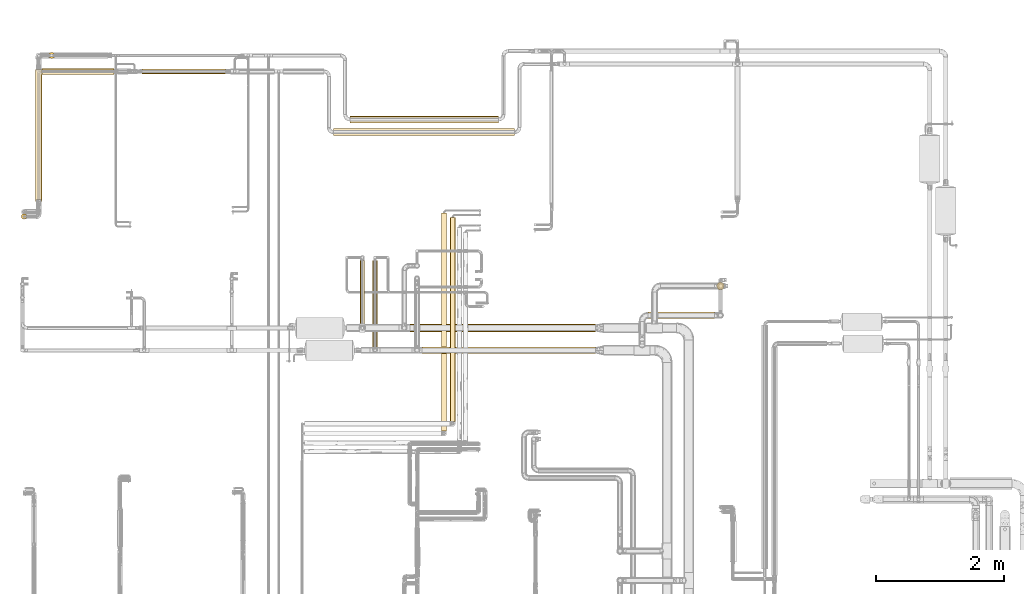
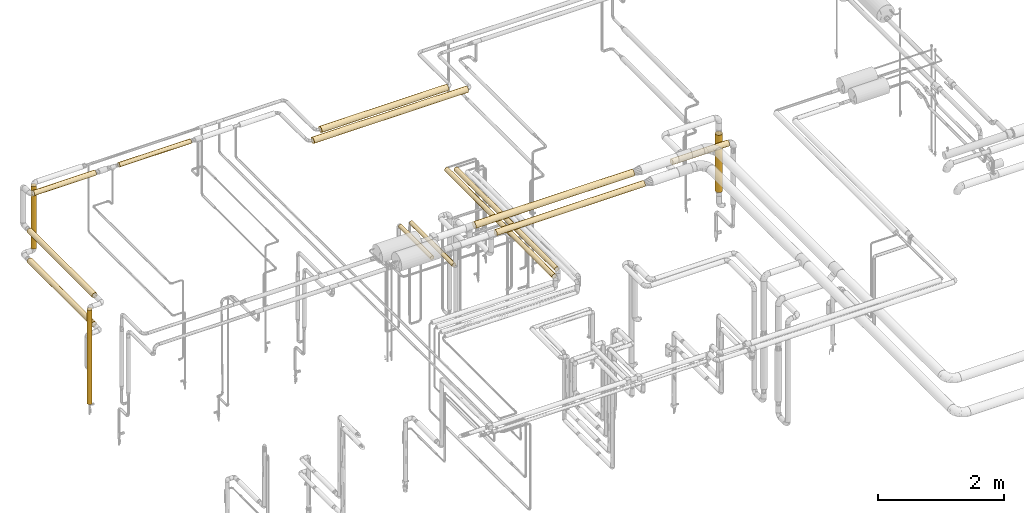
# One storey, part 3 of 827: 16 coverings.
"""IFC2X3 building model written with IfcOpenShell, lengths in millimetres."""

from ifc_helpers import new_model, entity, si_unit, converted_unit, derived_unit, direction, frame, origin, origin_2d_with_axis, place, context, subcontext, project, spatial, circle, extrude, element, save


model = new_model("IFC2X3")

# Units and contexts
model_context = context("Model", 3, precision=0.01, world=origin(), true_north=direction((6.12303176911189e-17, 1.0)))
body_context = subcontext(model_context, "Body", "Model", "MODEL_VIEW")
ifc_project = project(units=[si_unit("LENGTHUNIT", "METRE", prefix="MILLI"), si_unit("AREAUNIT", "SQUARE_METRE"), si_unit("VOLUMEUNIT", "CUBIC_METRE"), converted_unit("PLANEANGLEUNIT", "DEGREE", entity("IfcRatioMeasure", 0.0174532925199433), si_unit("PLANEANGLEUNIT", "RADIAN"), dimensions=[0, 0, 0, 0, 0, 0, 0]), si_unit("MASSUNIT", "GRAM", prefix="KILO"), derived_unit("MASSDENSITYUNIT", [(si_unit("MASSUNIT", "GRAM", prefix="KILO"), 1), (si_unit("LENGTHUNIT", "METRE"), -3)]), derived_unit("MOMENTOFINERTIAUNIT", [(si_unit("LENGTHUNIT", "METRE"), 4)]), si_unit("TIMEUNIT", "SECOND"), si_unit("FREQUENCYUNIT", "HERTZ"), si_unit("THERMODYNAMICTEMPERATUREUNIT", "DEGREE_CELSIUS"), derived_unit("THERMALTRANSMITTANCEUNIT", [(si_unit("MASSUNIT", "GRAM", prefix="KILO"), 1), (si_unit("THERMODYNAMICTEMPERATUREUNIT", "KELVIN"), -1), (si_unit("TIMEUNIT", "SECOND"), -3)]), derived_unit("VOLUMETRICFLOWRATEUNIT", [(si_unit("LENGTHUNIT", "METRE"), 3), (si_unit("TIMEUNIT", "SECOND"), -1)]), derived_unit("MASSFLOWRATEUNIT", [(si_unit("MASSUNIT", "GRAM", prefix="KILO"), 1), (si_unit("TIMEUNIT", "SECOND"), -1)]), derived_unit("ROTATIONALFREQUENCYUNIT", [(si_unit("TIMEUNIT", "SECOND"), -1)]), si_unit("ELECTRICCURRENTUNIT", "AMPERE"), si_unit("ELECTRICVOLTAGEUNIT", "VOLT"), si_unit("POWERUNIT", "WATT"), si_unit("FORCEUNIT", "NEWTON", prefix="KILO"), si_unit("ILLUMINANCEUNIT", "LUX"), si_unit("LUMINOUSFLUXUNIT", "LUMEN"), si_unit("LUMINOUSINTENSITYUNIT", "CANDELA"), derived_unit("USERDEFINED", [(si_unit("MASSUNIT", "GRAM", prefix="KILO"), -1), (si_unit("LENGTHUNIT", "METRE"), -2), (si_unit("TIMEUNIT", "SECOND"), 3), (si_unit("LUMINOUSFLUXUNIT", "LUMEN"), 1)]), derived_unit("LINEARVELOCITYUNIT", [(si_unit("LENGTHUNIT", "METRE"), 1), (si_unit("TIMEUNIT", "SECOND"), -1)]), si_unit("PRESSUREUNIT", "PASCAL"), derived_unit("USERDEFINED", [(si_unit("LENGTHUNIT", "METRE"), -2), (si_unit("MASSUNIT", "GRAM", prefix="KILO"), 1), (si_unit("TIMEUNIT", "SECOND"), -2)]), derived_unit("LINEARFORCEUNIT", [(si_unit("MASSUNIT", "GRAM", prefix="KILO"), 1), (si_unit("LENGTHUNIT", "METRE"), 1), (si_unit("TIMEUNIT", "SECOND"), -2), (si_unit("LENGTHUNIT", "METRE"), -1)]), derived_unit("PLANARFORCEUNIT", [(si_unit("MASSUNIT", "GRAM", prefix="KILO"), 1), (si_unit("LENGTHUNIT", "METRE"), 1), (si_unit("TIMEUNIT", "SECOND"), -2), (si_unit("LENGTHUNIT", "METRE"), -2)])], contexts=[model_context])

# Site, building, storey
site_placement = place(None, origin())
site = spatial("IfcSite", under=ifc_project, at=site_placement, CompositionType="ELEMENT")
building_placement = place(site_placement, origin())
building = spatial("IfcBuilding", under=site, at=building_placement, CompositionType="ELEMENT")
storey_placement = place(building_placement, frame((0.0, 0.0, 28200.0)))
storey = spatial("IfcBuildingStorey", under=building, at=storey_placement, Name="08", CompositionType="ELEMENT", Elevation=28200.0)

# Coverings
covering_1_placement = place(storey_placement, frame((13617.95, 18721.38, 2958.4)))
element("IfcCovering", 1, at=covering_1_placement, inside=storey, Name=":ADSK_", ObjectType=":ADSK_", PredefinedType="INSULATION", context=body_context, shape_type="SweptSolid", body=[
    extrude(circle(Radius=40.0, at=origin_2d_with_axis()), frame((0.0, 41.6, 41.6), z_axis=(1.0, 0.0, 0.0), x_axis=(0.0, 1.0, 0.0)), (0.0, 0.0, 1.0), 1312.94608002415),
])
covering_2_placement = place(storey_placement, frame((17228.97, 14448.0, 2362.25)))
element("IfcCovering", 2, at=covering_2_placement, inside=storey, Name=":ADSK_", ObjectType=":ADSK_", PredefinedType="INSULATION", context=body_context, shape_type="SweptSolid", body=[
    extrude(circle(Radius=36.15, at=origin_2d_with_axis()), frame((37.75, 0.0, 37.75), z_axis=(0.0, 1.0, 0.0), x_axis=(-1.0, 0.0, 0.0)), (0.0, 0.0, 1.0), 1355.78810636395),
])
covering_3_placement = place(storey_placement, frame((17030.62, 14797.79, 2362.25)))
element("IfcCovering", 3, at=covering_3_placement, inside=storey, Name=":ADSK_", ObjectType=":ADSK_", PredefinedType="INSULATION", context=body_context, shape_type="SweptSolid", body=[
    extrude(circle(Radius=36.15, at=origin_2d_with_axis()), frame((37.75, 0.0, 37.75), z_axis=(0.0, 1.0, 0.0), x_axis=(1.0, 0.0, 0.0)), (0.0, 0.0, 1.0), 1005.99246062177),
])
covering_4_placement = place(storey_placement, frame((17810.74, 14688.7, 2738.9)))
element("IfcCovering", 4, at=covering_4_placement, inside=storey, Name=":ADSK_", ObjectType=":ADSK_", PredefinedType="INSULATION", context=body_context, shape_type="SweptSolid", body=[
    extrude(circle(Radius=59.5, at=origin_2d_with_axis()), frame((0.0, 61.1, 61.1), z_axis=(1.0, 0.0, 0.0), x_axis=(0.0, -1.0, 0.0)), (0.0, 0.0, 1.0), 2902.82745349198),
])
covering_5_placement = place(storey_placement, frame((22608.61, 15346.4, 1369.89)))
element("IfcCovering", 5, at=covering_5_placement, inside=storey, Name=":ADSK_", ObjectType=":ADSK_", PredefinedType="INSULATION", context=body_context, shape_type="SweptSolid", body=[
    extrude(circle(Radius=59.25, at=origin_2d_with_axis()), frame((60.85, 60.85, 0.0), z_axis=(0.0, 0.0, 1.0), x_axis=(0.0, -1.0, 0.0)), (0.0, 0.0, 1.0), 1110.0),
])
covering_6_placement = place(storey_placement, frame((21538.56, 14892.9, 2545.65)))
element("IfcCovering", 6, at=covering_6_placement, inside=storey, Name=":ADSK_", ObjectType=":ADSK_", PredefinedType="INSULATION", context=body_context, shape_type="SweptSolid", body=[
    extrude(circle(Radius=52.75, at=origin_2d_with_axis()), frame((0.0, 54.35, 54.35), z_axis=(1.0, 0.0, 0.0), x_axis=(0.0, 1.0, 0.0)), (0.0, 0.0, 1.0), 1035.89794397964),
])
covering_7_placement = place(storey_placement, frame((17998.29, 14345.4, 2745.39)))
element("IfcCovering", 7, at=covering_7_placement, inside=storey, Name=":ADSK_", ObjectType=":ADSK_", PredefinedType="INSULATION", context=body_context, shape_type="SweptSolid", body=[
    extrude(circle(Radius=53.0, at=origin_2d_with_axis()), frame((0.0, 54.6, 54.6), z_axis=(1.0, 0.0, 0.0), x_axis=(0.0, -1.0, 0.0)), (0.0, 0.0, 1.0), 2714.60697805768),
])
covering_8_placement = place(storey_placement, frame((16620.17, 17756.38, 2943.4)))
element("IfcCovering", 8, at=covering_8_placement, inside=storey, Name=":ADSK_", ObjectType=":ADSK_", PredefinedType="INSULATION", context=body_context, shape_type="SweptSolid", body=[
    extrude(circle(Radius=55.0, at=origin_2d_with_axis()), frame((0.0, 56.6, 56.6), z_axis=(1.0, 0.0, 0.0), x_axis=(0.0, 1.0, 0.0)), (0.0, 0.0, 1.0), 2828.00000000001),
])
covering_9_placement = place(storey_placement, frame((16875.06, 17956.2, 2943.4)))
element("IfcCovering", 9, at=covering_9_placement, inside=storey, Name=":ADSK_", ObjectType=":ADSK_", PredefinedType="INSULATION", context=body_context, shape_type="SweptSolid", body=[
    extrude(circle(Radius=55.0, at=origin_2d_with_axis()), frame((0.0, 56.6, 56.6), z_axis=(1.0, 0.0, 0.0), x_axis=(0.0, 1.0, 0.0)), (0.0, 0.0, 1.0), 2324.875),
])
covering_10_placement = place(storey_placement, frame((18437.21, 13288.0, 2556.65)))
element("IfcCovering", 10, at=covering_10_placement, inside=storey, Name=":ADSK_", ObjectType=":ADSK_", PredefinedType="INSULATION", context=body_context, shape_type="SweptSolid", body=[
    extrude(circle(Radius=41.75, at=origin_2d_with_axis()), frame((43.35, 0.0, 43.35), z_axis=(0.0, 1.0, 0.0), x_axis=(-1.0, 0.0, 0.0)), (0.0, 0.0, 1.0), 3191.91504634766),
])
covering_11_placement = place(storey_placement, frame((18302.21, 13138.0, 2556.65)))
element("IfcCovering", 11, at=covering_11_placement, inside=storey, Name=":ADSK_", ObjectType=":ADSK_", PredefinedType="INSULATION", context=body_context, shape_type="SweptSolid", body=[
    extrude(circle(Radius=41.75, at=origin_2d_with_axis()), frame((43.35, 0.0, 43.35), z_axis=(0.0, 1.0, 0.0), x_axis=(-1.0, 0.0, 0.0)), (0.0, 0.0, 1.0), 3410.60077364376),
])
covering_12_placement = place(storey_placement, frame((11731.87, 16451.3, 407.5)))
element("IfcCovering", 12, at=covering_12_placement, inside=storey, Name=":ADSK_", ObjectType=":ADSK_", PredefinedType="INSULATION", context=body_context, shape_type="SweptSolid", body=[
    extrude(circle(Radius=41.75, at=origin_2d_with_axis()), frame((43.35, 43.35, 0.0), z_axis=(0.0, 0.0, 1.0), x_axis=(0.0, -1.0, 0.0)), (0.0, 0.0, 1.0), 1824.7853679055),
])
covering_13_placement = place(storey_placement, frame((12053.46, 18715.23, 2952.25)))
element("IfcCovering", 13, at=covering_13_placement, inside=storey, Name=":ADSK_", ObjectType=":ADSK_", PredefinedType="INSULATION", context=body_context, shape_type="SweptSolid", body=[
    extrude(circle(Radius=46.15, at=origin_2d_with_axis()), frame((0.0, 47.75, 47.75), z_axis=(1.0, 0.0, 0.0), x_axis=(0.0, 1.0, 0.0)), (0.0, 0.0, 1.0), 1131.4301613299),
])
covering_14_placement = place(storey_placement, frame((11954.87, 16731.69, 2219.69)))
element("IfcCovering", 14, at=covering_14_placement, inside=storey, Name=":ADSK_", ObjectType=":ADSK_", PredefinedType="INSULATION", context=body_context, shape_type="SweptSolid", body=[
    extrude(circle(Radius=49.0, at=origin_2d_with_axis()), frame((50.6, 0.0, 50.6), z_axis=(0.0, 1.0, 0.0), x_axis=(1.0, 0.0, 0.0)), (0.0, 0.0, 1.0), 2064.72931793336),
])
covering_15_placement = place(storey_placement, frame((12158.2, 18965.72, 1742.27)))
element("IfcCovering", 15, at=covering_15_placement, inside=storey, Name=":ADSK_", ObjectType=":ADSK_", PredefinedType="INSULATION", context=body_context, shape_type="SweptSolid", body=[
    extrude(circle(Radius=46.15, at=origin_2d_with_axis()), frame((47.75, 47.75, 0.0), z_axis=(0.0, 0.0, 1.0), x_axis=(0.0, 1.0, 0.0)), (0.0, 0.0, 1.0), 1209.73020064811),
])
covering_16_placement = place(storey_placement, frame((11955.35, 16759.86, 1643.67)))
element("IfcCovering", 16, at=covering_16_placement, inside=storey, Name=":ADSK_", ObjectType=":ADSK_", PredefinedType="INSULATION", context=body_context, shape_type="SweptSolid", body=[
    extrude(circle(Radius=49.0, at=origin_2d_with_axis()), frame((50.6, 0.0, 50.6), z_axis=(0.0, 1.0, 0.0), x_axis=(-1.0, 0.0, 0.0)), (0.0, 0.0, 1.0), 2034.37525687381),
])

save(model, "model.ifc")
